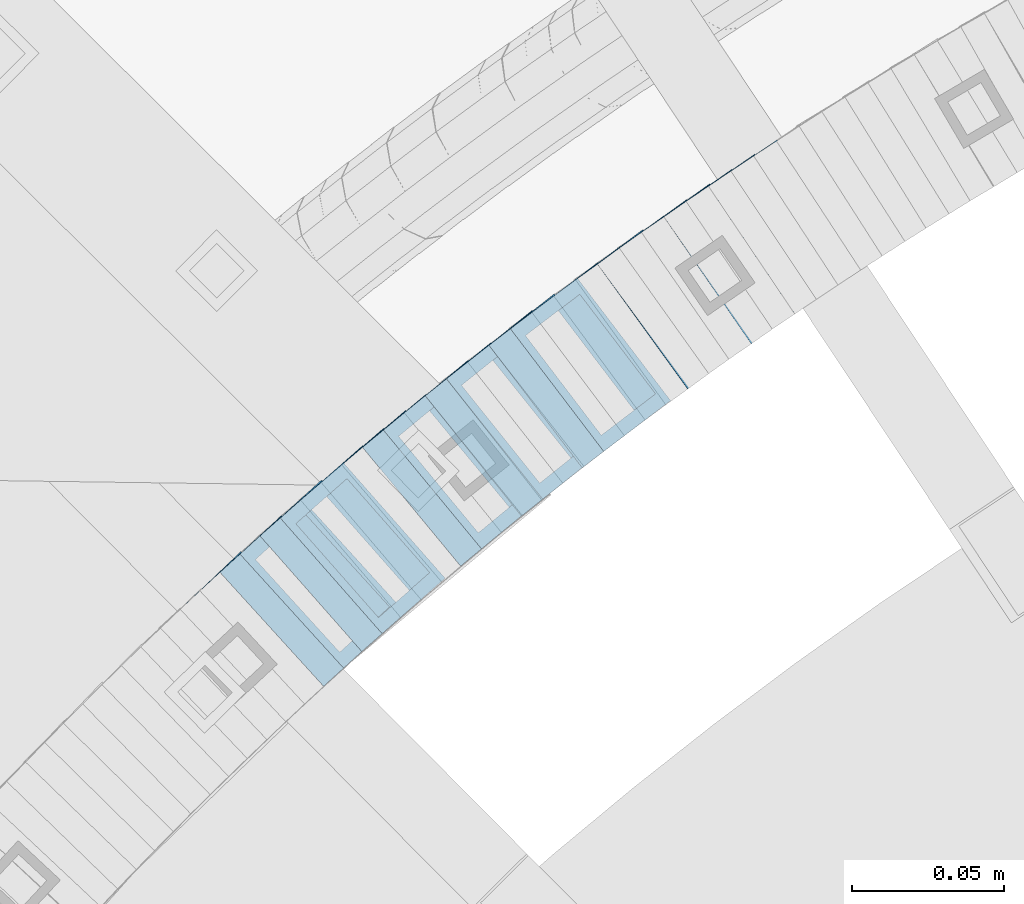
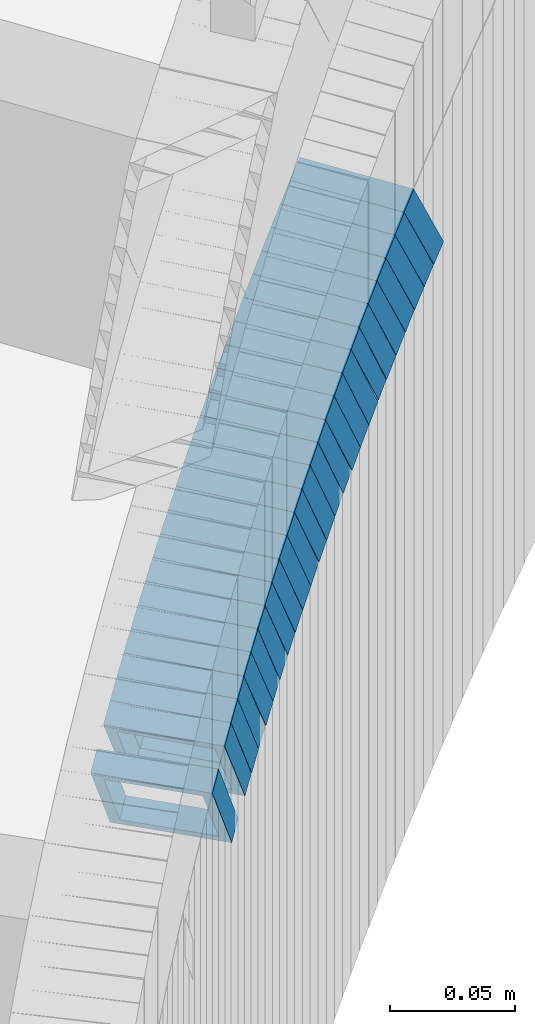
# One storey, part 749 of 975: 25 members.
"""IFC2X3 building model written with IfcOpenShell, lengths in millimetres."""

import ifcopenshell
import ifcopenshell.guid

model = None  # the IFC model being written
_history = None  # IfcOwnerHistory: only IFC2X3 demands one
_inside = {}  # id of a spatial element -> (the spatial element, [elements in it])
_under = {}  # id of a project, library or spatial element -> (it, [spatial elements below it])
_declared = {}  # id of a project -> (the project, [libraries it declares])
_typed = {}  # id of a type object -> (the type object, [elements of that type])
_made_of = {}  # id of a material, layer set ... -> (it, [elements and type objects made of it])


def new_model(schema):
    """Start an empty IFC model of exactly this schema.

    Asked for "IFC4X3", IfcOpenShell would pick the latest addendum, in which some entities
    have other attributes; the version numbers below select the first issue.
    IFC2X3 requires an IfcOwnerHistory on every rooted entity: one is made here for all.
    """
    global model, _history
    if schema == "IFC4X3":
        model = ifcopenshell.file(schema_version=(4, 3, 0, 0))
    else:
        model = ifcopenshell.file(schema=schema)
    _inside.clear()
    _under.clear()
    _declared.clear()
    _typed.clear()
    _made_of.clear()
    _history = None
    if model.schema == "IFC2X3":
        org = make("IfcOrganization", Name="unknown")
        user = make(
            "IfcPersonAndOrganization",
            ThePerson=make("IfcPerson", FamilyName="unknown"),
            TheOrganization=org,
        )
        app = make(
            "IfcApplication",
            ApplicationDeveloper=org,
            Version="unknown",
            ApplicationFullName="unknown",
            ApplicationIdentifier="unknown",
        )
        _history = make(
            "IfcOwnerHistory",
            OwningUser=user,
            OwningApplication=app,
            ChangeAction="ADDED",
            CreationDate=0,
        )
    return model


def make(cls, **values):
    """One entity of the class cls with the attributes given. An attribute that is None is left unset."""
    return model.create_entity(
        cls, **{name: value for name, value in values.items() if value is not None}
    )


def rooted(cls, **values):
    """An entity with a GlobalId (a new one), such as an element, a storey or a relation."""
    return make(cls, GlobalId=ifcopenshell.guid.new(), OwnerHistory=_history, **values)


def si_unit(unit_type, name, prefix=None):
    """IfcSIUnit, for example si_unit("LENGTHUNIT", "METRE", prefix="MILLI")."""
    return make("IfcSIUnit", UnitType=unit_type, Prefix=prefix, Name=name)


def assignment(units):
    """IfcUnitAssignment: the units of a project."""
    return None if units is None else make("IfcUnitAssignment", Units=units)


def point(xyz):
    """IfcCartesianPoint."""
    return None if xyz is None else make("IfcCartesianPoint", Coordinates=xyz)


def direction(xyz):
    """IfcDirection."""
    return None if xyz is None else make("IfcDirection", DirectionRatios=xyz)


def frame(location, z_axis=None, x_axis=None):
    """IfcAxis2Placement3D, a coordinate frame: its origin and axes. An axis left out is left unset."""
    return make(
        "IfcAxis2Placement3D",
        Location=point(location),
        Axis=direction(z_axis),
        RefDirection=direction(x_axis),
    )


def origin_with_axes():
    """The frame at (0, 0, 0) with the z axis (0, 0, 1) and the x axis (1, 0, 0) written out."""
    return frame((0.0, 0.0, 0.0), z_axis=(0.0, 0.0, 1.0), x_axis=(1.0, 0.0, 0.0))


def place(relative_to, where):
    """IfcLocalPlacement: puts the frame where relative to a parent placement (None: the world)."""
    return make(
        "IfcLocalPlacement", PlacementRelTo=relative_to, RelativePlacement=where
    )


def context(
    kind, dimensions, precision=None, world=None, true_north=None, identifier=None
):
    """IfcGeometricRepresentationContext, for example the 3D "Model" context."""
    return make(
        "IfcGeometricRepresentationContext",
        ContextIdentifier=identifier,
        ContextType=kind,
        CoordinateSpaceDimension=dimensions,
        Precision=precision,
        WorldCoordinateSystem=world,
        TrueNorth=true_north,
    )


def subcontext(parent, identifier, kind, view, scale=None):
    """IfcGeometricRepresentationSubContext, for example "Body" below "Model"."""
    return make(
        "IfcGeometricRepresentationSubContext",
        ContextIdentifier=identifier,
        ContextType=kind,
        ParentContext=parent,
        TargetScale=scale,
        TargetView=view,
    )


def project(units=None, contexts=None):
    """IfcProject with its units and contexts."""
    return rooted(
        "IfcProject",
        Name="project",
        RepresentationContexts=contexts,
        UnitsInContext=assignment(units),
    )


def spatial(cls, under=None, at=None, **own):
    """A site, building, storey or space (cls), placed at a placement, below another one or the project."""
    s = rooted(cls, ObjectPlacement=at, **own)
    if under is not None:
        _under.setdefault(under.id(), (under, []))[1].append(s)
    return s


def faces_of(points, faces, orient=None, outer=None):
    """IfcFace entities. A face is a list of loops; a loop is a list of indices into points, from 0.

    orient and outer hold one flag for each loop. By default every Orientation is true, the
    first loop of a face is its IfcFaceOuterBound and the others are IfcFaceBound.
    """
    made = []
    for i, loops in enumerate(faces):
        bounds = []
        for j, loop in enumerate(loops):
            is_outer = j == 0 if outer is None else outer[i][j]
            bounds.append(
                make(
                    "IfcFaceOuterBound" if is_outer else "IfcFaceBound",
                    Bound=make("IfcPolyLoop", Polygon=[points[k] for k in loop]),
                    Orientation=True if orient is None else orient[i][j],
                )
            )
        made.append(make("IfcFace", Bounds=bounds))
    return made


def faceted_brep(points, faces, orient=None, outer=None, voids=None):
    """IfcFacetedBrep: a solid bounded by flat faces; with voids (closed shells), ...WithVoids."""
    shared = [point(p) for p in points]
    hull = make("IfcClosedShell", CfsFaces=faces_of(shared, faces, orient, outer))
    if voids is None:
        return make("IfcFacetedBrep", Outer=hull)
    return make(
        "IfcFacetedBrepWithVoids",
        Outer=hull,
        Voids=[
            make(cls, CfsFaces=faces_of(shared, fs, o, b)) for cls, fs, o, b in voids
        ],
    )


def shape(context_of_items, identifier, shape_type, items):
    """IfcShapeRepresentation: the items that make up one representation, for example the "Body"."""
    return make(
        "IfcShapeRepresentation",
        ContextOfItems=context_of_items,
        RepresentationIdentifier=identifier,
        RepresentationType=shape_type,
        Items=items,
    )


def material(Name=None, Category=None):
    """IfcMaterial."""
    return make("IfcMaterial", Name=Name, Category=Category)


def made_of(thing, what):
    """Note that an element or type object is made of a material, layer set ...; save() writes the relation."""
    if what is not None:
        _made_of.setdefault(what.id(), (what, []))[1].append(thing)
    return thing


def type_object(cls, material=None, **own):
    """A type object (cls), such as IfcWallType, which elements share."""
    return made_of(rooted(cls, **own), material)


def element(
    cls,
    number,
    at=None,
    inside=None,
    cuts=None,
    type_object=None,
    material=None,
    context=None,
    identifier="Body",
    shape_type=None,
    held_by="IfcProductDefinitionShape",
    body=None,
    shapes=None,
    **own,
):
    """One element of the class cls, such as IfcWall. Its Tag is "e" and its number.

    at: its placement. inside: the storey or other place that contains it. cuts: it is an
    opening in that element (IfcRelVoidsElement). A single representation is given by context,
    identifier, shape_type and body (its items); several are given by shapes. held_by: the class
    of the entity that holds the representations. save() writes the other relations.
    """
    e = rooted(cls, Tag="e%d" % number, ObjectPlacement=at, **own)
    if body is not None:
        shapes = [shape(context, identifier, shape_type, body)]
    if shapes is not None:
        e.Representation = make(held_by, Representations=shapes)
    if inside is not None:
        _inside.setdefault(inside.id(), (inside, []))[1].append(e)
    if cuts is not None:
        rooted(
            "IfcRelVoidsElement", RelatingBuildingElement=cuts, RelatedOpeningElement=e
        )
    if type_object is not None:
        _typed.setdefault(type_object.id(), (type_object, []))[1].append(e)
    return made_of(e, material)


def aggregate(whole, parts):
    """IfcRelAggregates: a whole, such as a stair, and the parts it consists of."""
    return rooted("IfcRelAggregates", RelatingObject=whole, RelatedObjects=parts)


def save(model, path):
    """Write the relations noted so far, then the file.

    IfcRelAggregates (storeys below a building ...), IfcRelContainedInSpatialStructure (elements
    in a storey), IfcRelDefinesByType, IfcRelAssociatesMaterial and IfcRelDeclares: one each for
    every whole, place, type object, material and project.
    """
    for whole, parts in _under.values():
        aggregate(whole, parts)
    for where, things in _inside.values():
        rooted(
            "IfcRelContainedInSpatialStructure",
            RelatedElements=things,
            RelatingStructure=where,
        )
    for kind, things in _typed.values():
        rooted("IfcRelDefinesByType", RelatedObjects=things, RelatingType=kind)
    for what, things in _made_of.values():
        rooted("IfcRelAssociatesMaterial", RelatedObjects=things, RelatingMaterial=what)
    for by, libraries in _declared.values():
        rooted("IfcRelDeclares", RelatingContext=by, RelatedDefinitions=libraries)
    model.write(path)


model = new_model("IFC2X3")

# Units and contexts
model_context = context("Model", 3, precision=1e-05, world=origin_with_axes())
body_context = subcontext(model_context, "Body", "Model", "MODEL_VIEW")
ifc_project = project(units=[si_unit("LENGTHUNIT", "METRE", prefix="MILLI"), si_unit("AREAUNIT", "SQUARE_METRE"), si_unit("VOLUMEUNIT", "CUBIC_METRE"), si_unit("MASSUNIT", "GRAM", prefix="KILO"), si_unit("TIMEUNIT", "SECOND"), si_unit("PLANEANGLEUNIT", "RADIAN"), si_unit("SOLIDANGLEUNIT", "STERADIAN"), si_unit("THERMODYNAMICTEMPERATUREUNIT", "DEGREE_CELSIUS"), si_unit("LUMINOUSINTENSITYUNIT", "LUMEN")], contexts=[model_context])

# Site, building, storey
site_placement = place(None, origin_with_axes())
site = spatial("IfcSite", under=ifc_project, at=site_placement, CompositionType="ELEMENT")
building_placement = place(site_placement, origin_with_axes())
building = spatial("IfcBuilding", under=site, at=building_placement, Name="Undefined", CompositionType="ELEMENT")
storey_placement = place(building_placement, origin_with_axes())
storey = spatial("IfcBuildingStorey", under=building, at=storey_placement, Name="Undefined", CompositionType="ELEMENT", Elevation=0.0)

# Members
ifc_material = material()
member_type = type_object("IfcMemberType", Name="HSS2X2X.188_TUBES", PredefinedType="NOTDEFINED")
member_1_placement = place(storey_placement, frame((33945.6299849919, 4556.65921990067, 489.058410364057), z_axis=(-0.567472910723373, 0.823392066755044, 5.72851490687754e-11), x_axis=(0.69183053606331, 0.476802126043426, 0.542245555049391)))
element("IfcMember", 1, at=member_1_placement, inside=storey, type_object=member_type, material=ifc_material, Name="WALL", ObjectType="HSS2X2X.188_TUBES", context=body_context, shape_type="Brep", body=[
    faceted_brep([(0.0, 20.6374999999753, -20.6375000000298), (0.0, -20.6375000000153, -20.6375000000153), (10.6985980389491, -20.6375000000317, -20.6375000000698), (10.6985980389982, 20.6375000000116, -20.6374999999643), (0.0, -20.6374999999825, 20.6375000000335), (10.6985980389818, -20.6374999999989, 20.6374999999789), (0.0, 20.6375000000116, 20.6375000000189), (10.6985980390309, 20.6375000000407, 20.6375000000808), (0.0, 25.3999999999724, -25.4000000000342), (0.0, 25.400000000016, 25.4000000000196), (10.6985980390382, 25.4000000000487, 25.4000000000997), (10.6985980390036, 25.4000000000142, -25.3999999999542), (0.0, -25.399999999976, 25.4000000000378), (10.6985980389763, -25.4000000000033, 25.3999999999724), (0.0, -25.400000000016, -25.4000000000196), (10.6985980389418, -25.400000000036, -25.4000000000851)], [[[0, 1, 2, 3]], [[1, 4, 5, 2]], [[4, 6, 7, 5]], [[6, 0, 3, 7]], [[8, 9, 10, 11]], [[9, 12, 13, 10]], [[12, 14, 15, 13]], [[14, 8, 11, 15]], [[13, 15, 11, 10], [5, 7, 3, 2]], [[14, 12, 9, 8], [6, 4, 1, 0]]]),
])
member_2_placement = place(storey_placement, frame((33938.3475391302, 4551.67792072492, 483.307140848893), z_axis=(-0.572708438875059, 0.819759137821161, 0.0), x_axis=(0.690432747898091, 0.482357124929043, 0.539105021920664)))
element("IfcMember", 2, at=member_2_placement, inside=storey, type_object=member_type, material=ifc_material, Name="WALL", ObjectType="HSS2X2X.188_TUBES", context=body_context, shape_type="Brep", body=[
    faceted_brep([(0.0, 20.6374999999753, -20.6375000000298), (0.0, -20.6375000000153, -20.6375000000153), (10.5744976239494, -20.6375000000207, -20.6375000000335), (10.5744976239657, 20.6375000000098, -20.637500000008), (0.0, -20.6374999999825, 20.6375000000335), (10.5744976239639, -20.6375000000244, 20.6374999999753), (0.0, 20.6375000000116, 20.6375000000189), (10.5744976239803, 20.6374999999989, 20.6374999999935), (0.0, 25.3999999999724, -25.4000000000342), (0.0, 25.400000000016, 25.4000000000196), (10.5744976239857, 25.4000000000051, 25.4000000000015), (10.5744976239675, 25.4000000000124, -25.4000000000051), (0.0, -25.399999999976, 25.4000000000378), (10.5744976239639, -25.4000000000287, 25.3999999999724), (0.0, -25.400000000016, -25.4000000000196), (10.5744976239494, -25.4000000000215, -25.4000000000378)], [[[0, 1, 2, 3]], [[1, 4, 5, 2]], [[4, 6, 7, 5]], [[6, 0, 3, 7]], [[8, 9, 10, 11]], [[9, 12, 13, 10]], [[12, 14, 15, 13]], [[14, 8, 11, 15]], [[13, 15, 11, 10], [5, 7, 3, 2]], [[14, 12, 9, 8], [6, 4, 1, 0]]]),
])
member_3_placement = place(storey_placement, frame((33931.2517820136, 4546.77587397339, 477.575575193324), z_axis=(-0.580182279825393, 0.81448666175488, 0.0), x_axis=(0.683797621876668, 0.487088716912246, 0.543291260902102)))
element("IfcMember", 3, at=member_3_placement, inside=storey, type_object=member_type, material=ifc_material, Name="WALL", ObjectType="HSS2X2X.188_TUBES", context=body_context, shape_type="Brep", body=[
    faceted_brep([(0.0, 20.6374999999753, -20.6375000000298), (0.0, -20.6375000000153, -20.6375000000153), (10.6831643251735, -20.6375000000498, -20.6375000000953), (10.6831643252044, 20.637499999988, -20.6375000000226), (0.0, -20.6374999999825, 20.6375000000335), (10.6831643251935, -20.6375000000135, 20.637499999968), (0.0, 20.6375000000116, 20.6375000000189), (10.6831643252244, 20.6375000000226, 20.6375000000407), (0.0, 25.3999999999724, -25.4000000000342), (0.0, 25.400000000016, 25.4000000000196), (10.6831643252317, 25.4000000000306, 25.4000000000597), (10.6831643252044, 25.3999999999905, -25.4000000000196), (0.0, -25.399999999976, 25.4000000000378), (10.6831643251917, -25.400000000016, 25.3999999999614), (0.0, -25.400000000016, -25.4000000000196), (10.6831643251644, -25.400000000056, -25.4000000001179)], [[[0, 1, 2, 3]], [[1, 4, 5, 2]], [[4, 6, 7, 5]], [[6, 0, 3, 7]], [[8, 9, 10, 11]], [[9, 12, 13, 10]], [[12, 14, 15, 13]], [[14, 8, 11, 15]], [[13, 15, 11, 10], [5, 7, 3, 2]], [[14, 12, 9, 8], [6, 4, 1, 0]]]),
])
member_4_placement = place(storey_placement, frame((33924.0687833559, 4541.69868255447, 471.823674329394), z_axis=(-0.58549055413645, 0.810679228188926, 0.0), x_axis=(0.682257607152639, 0.492741605110064, 0.540120605120664)))
element("IfcMember", 4, at=member_4_placement, inside=storey, type_object=member_type, material=ifc_material, Name="WALL", ObjectType="HSS2X2X.188_TUBES", context=body_context, shape_type="Brep", body=[
    faceted_brep([(0.0, 20.6374999999753, -20.6375000000298), (0.0, -20.6375000000153, -20.6375000000153), (10.5531985672587, -20.6374999999916, -20.6375000000007), (10.5531985672878, 20.6375000000062, -20.6374999999789), (0.0, -20.6374999999825, 20.6375000000335), (10.5531985672114, -20.6375000000353, 20.6374999999171), (0.0, 20.6375000000116, 20.6375000000189), (10.5531985672333, 20.6374999999607, 20.6374999999316), (0.0, 25.3999999999724, -25.4000000000342), (0.0, 25.400000000016, 25.4000000000196), (10.5531985672314, 25.399999999956, 25.3999999999251), (10.5531985672933, 25.4000000000106, -25.3999999999724), (0.0, -25.399999999976, 25.4000000000378), (10.5531985672023, -25.4000000000397, 25.3999999999069), (0.0, -25.400000000016, -25.4000000000196), (10.5531985672642, -25.3999999999851, -25.3999999999869)], [[[0, 1, 2, 3]], [[1, 4, 5, 2]], [[4, 6, 7, 5]], [[6, 0, 3, 7]], [[8, 9, 10, 11]], [[9, 12, 13, 10]], [[12, 14, 15, 13]], [[14, 8, 11, 15]], [[13, 15, 11, 10], [5, 7, 3, 2]], [[14, 12, 9, 8], [6, 4, 1, 0]]]),
])
member_5_placement = place(storey_placement, frame((33916.6775082242, 4536.37463675579, 466.027238584625), z_axis=(-0.587512386110765, 0.809215172970969, -6.74122020427604e-11), x_axis=(0.684097809103072, 0.496673752074743, 0.534158564080343)))
element("IfcMember", 5, at=member_5_placement, inside=storey, type_object=member_type, material=ifc_material, Name="WALL", ObjectType="HSS2X2X.188_TUBES", context=body_context, shape_type="Brep", body=[
    faceted_brep([(0.0, 20.6374999999753, -20.6375000000298), (0.0, -20.6375000000153, -20.6375000000153), (10.6709887076922, -20.6374999999844, -20.6374999999825), (10.6709887076995, 20.6375000000171, -20.6374999999753), (0.0, -20.6374999999825, 20.6375000000335), (10.6709887076922, -20.6374999999971, 20.6375000000153), (0.0, 20.6375000000116, 20.6375000000189), (10.6709887076941, 20.6375000000025, 20.6375000000189), (0.0, 25.3999999999724, -25.4000000000342), (0.0, 25.400000000016, 25.4000000000196), (10.6709887076959, 25.3999999999996, 25.4000000000233), (10.6709887077013, 25.4000000000178, -25.3999999999724), (0.0, -25.399999999976, 25.4000000000378), (10.6709887076904, -25.3999999999978, 25.400000000016), (0.0, -25.400000000016, -25.4000000000196), (10.6709887076959, -25.3999999999796, -25.3999999999796)], [[[0, 1, 2, 3]], [[1, 4, 5, 2]], [[4, 6, 7, 5]], [[6, 0, 3, 7]], [[8, 9, 10, 11]], [[9, 12, 13, 10]], [[12, 14, 15, 13]], [[14, 8, 11, 15]], [[13, 15, 11, 10], [5, 7, 3, 2]], [[14, 12, 9, 8], [6, 4, 1, 0]]]),
])
member_6_placement = place(storey_placement, frame((33952.8187602865, 4561.46194615284, 494.789189186807), z_axis=(-0.559857410943981, 0.8285889689171, 0.0), x_axis=(0.698455183967749, 0.471929177977992, 0.537999262974955)))
element("IfcMember", 6, at=member_6_placement, inside=storey, type_object=member_type, material=ifc_material, Name="WALL", ObjectType="HSS2X2X.188_TUBES", context=body_context, shape_type="Brep", body=[
    faceted_brep([(0.0, 20.6374999999753, -20.6375000000298), (0.0, -20.6375000000153, -20.6375000000153), (10.5948100501191, -20.6375000000335, -20.6375000000844), (10.5948100501555, 20.6374999999971, -20.6375000000116), (0.0, -20.6374999999825, 20.6375000000335), (10.5948100501446, -20.6375000000098, 20.6374999999571), (0.0, 20.6375000000116, 20.6375000000189), (10.5948100501828, 20.6375000000189, 20.6375000000298), (0.0, 25.3999999999724, -25.4000000000342), (0.0, 25.400000000016, 25.4000000000196), (10.5948100501919, 25.4000000000251, 25.4000000000451), (10.5948100501591, 25.3999999999978, -25.4000000000051), (0.0, -25.399999999976, 25.4000000000378), (10.5948100501482, -25.4000000000106, 25.3999999999578), (0.0, -25.400000000016, -25.4000000000196), (10.5948100501118, -25.4000000000378, -25.400000000096)], [[[0, 1, 2, 3]], [[1, 4, 5, 2]], [[4, 6, 7, 5]], [[6, 0, 3, 7]], [[8, 9, 10, 11]], [[9, 12, 13, 10]], [[12, 14, 15, 13]], [[14, 8, 11, 15]], [[13, 15, 11, 10], [5, 7, 3, 2]], [[14, 12, 9, 8], [6, 4, 1, 0]]]),
])
member_7_placement = place(storey_placement, frame((33902.5878218631, 4526.09174665678, 454.541595500078), z_axis=(-0.599999999999955, 0.800000000000033, 3.66071617463603e-14), x_axis=(0.675855260383161, 0.506891445287285, 0.535052081303285)))
element("IfcMember", 7, at=member_7_placement, inside=storey, type_object=member_type, material=ifc_material, Name="WALL", ObjectType="HSS2X2X.188_TUBES", context=body_context, shape_type="Brep", body=[
    faceted_brep([(0.0, 20.6374999999753, -20.6375000000298), (0.0, -20.6375000000153, -20.6375000000153), (10.648004507897, -20.6374999999862, -20.637499999968), (10.6480045078188, 20.6374999999771, -20.6375000000808), (0.0, -20.6374999999825, 20.6375000000335), (10.6480045079406, -20.6374999999698, 20.6375000001062), (0.0, 20.6375000000116, 20.6375000000189), (10.6480045078679, 20.6374999999935, 20.6375000000007), (0.0, 25.3999999999724, -25.4000000000342), (0.0, 25.400000000016, 25.4000000000196), (10.6480045078661, 25.3999999999905, 25.4000000000015), (10.648004507806, 25.3999999999705, -25.4000000000997), (0.0, -25.399999999976, 25.4000000000378), (10.6480045079552, -25.3999999999633, 25.4000000001288), (0.0, -25.400000000016, -25.4000000000196), (10.6480045078988, -25.3999999999814, -25.3999999999651)], [[[0, 1, 2, 3]], [[1, 4, 5, 2]], [[4, 6, 7, 5]], [[6, 0, 3, 7]], [[8, 9, 10, 11]], [[9, 12, 13, 10]], [[12, 14, 15, 13]], [[14, 8, 11, 15]], [[13, 15, 11, 10], [5, 7, 3, 2]], [[14, 12, 9, 8], [6, 4, 1, 0]]]),
])
member_8_placement = place(storey_placement, frame((33895.6378623201, 4520.91998783105, 448.89658431469), z_axis=(-0.605367471213059, 0.795946119280134, 0.0), x_axis=(0.670707309990764, 0.510115418993113, 0.538455163992726)))
element("IfcMember", 8, at=member_8_placement, inside=storey, type_object=member_type, material=ifc_material, Name="WALL", ObjectType="HSS2X2X.188_TUBES", context=body_context, shape_type="Brep", body=[
    faceted_brep([(0.0, 20.6374999999753, -20.6375000000298), (0.0, -20.6375000000153, -20.6375000000153), (10.5948100501191, -20.6375000000335, -20.6375000000844), (10.5948100501555, 20.6374999999971, -20.6375000000116), (0.0, -20.6374999999825, 20.6375000000335), (10.5948100501446, -20.6375000000098, 20.6374999999571), (0.0, 20.6375000000116, 20.6375000000189), (10.5948100501828, 20.6375000000189, 20.6375000000298), (0.0, 25.3999999999724, -25.4000000000342), (0.0, 25.400000000016, 25.4000000000196), (10.5948100501919, 25.4000000000251, 25.4000000000451), (10.5948100501591, 25.3999999999978, -25.4000000000051), (0.0, -25.399999999976, 25.4000000000378), (10.5948100501482, -25.4000000000106, 25.3999999999578), (0.0, -25.400000000016, -25.4000000000196), (10.5948100501118, -25.4000000000378, -25.400000000096)], [[[0, 1, 2, 3]], [[1, 4, 5, 2]], [[4, 6, 7, 5]], [[6, 0, 3, 7]], [[8, 9, 10, 11]], [[9, 12, 13, 10]], [[12, 14, 15, 13]], [[14, 8, 11, 15]], [[13, 15, 11, 10], [5, 7, 3, 2]], [[14, 12, 9, 8], [6, 4, 1, 0]]]),
])
member_9_placement = place(storey_placement, frame((33888.6724401165, 4515.62234277477, 443.205570956088), z_axis=(-0.605367471213059, 0.795946119280134, 0.0), x_axis=(0.66729205421176, 0.507517900161024, 0.545111819172905)))
element("IfcMember", 9, at=member_9_placement, inside=storey, type_object=member_type, material=ifc_material, Name="WALL", ObjectType="HSS2X2X.188_TUBES", context=body_context, shape_type="Brep", body=[
    faceted_brep([(0.0, 20.6374999999753, -20.6375000000298), (0.0, -20.6375000000153, -20.6375000000153), (10.6395488625676, -20.6374999999771, -20.6374999999716), (10.6395488625531, 20.6374999999916, -20.6375000000189), (0.0, -20.6374999999825, 20.6375000000335), (10.6395488625731, -20.6374999999844, 20.6375000000153), (0.0, 20.6375000000116, 20.6375000000189), (10.6395488625585, 20.6374999999825, 20.637499999968), (0.0, 25.3999999999724, -25.4000000000342), (0.0, 25.400000000016, 25.4000000000196), (10.6395488625567, 25.3999999999778, 25.3999999999614), (10.6395488625494, 25.3999999999887, -25.4000000000233), (0.0, -25.399999999976, 25.4000000000378), (10.6395488625749, -25.3999999999851, 25.400000000016), (0.0, -25.400000000016, -25.4000000000196), (10.6395488625658, -25.399999999976, -25.3999999999687)], [[[0, 1, 2, 3]], [[1, 4, 5, 2]], [[4, 6, 7, 5]], [[6, 0, 3, 7]], [[8, 9, 10, 11]], [[9, 12, 13, 10]], [[12, 14, 15, 13]], [[14, 8, 11, 15]], [[13, 15, 11, 10], [5, 7, 3, 2]], [[14, 12, 9, 8], [6, 4, 1, 0]]]),
])
member_10_placement = place(storey_placement, frame((33910.0178610049, 4531.62510266129, 460.448564624512), z_axis=(-0.598192606862824, 0.801352360135452, 1.24999814943294e-10), x_axis=(0.670468028116059, 0.500490218086671, 0.547706276094879)))
element("IfcMember", 10, at=member_10_placement, inside=storey, type_object=member_type, material=ifc_material, Name="WALL", ObjectType="HSS2X2X.188_TUBES", context=body_context, shape_type="Brep", body=[
    faceted_brep([(0.0, 20.6374999999753, -20.6375000000298), (0.0, -20.6375000000153, -20.6375000000153), (10.5948100501191, -20.6375000000335, -20.6375000000844), (10.5948100501555, 20.6374999999971, -20.6375000000116), (0.0, -20.6374999999825, 20.6375000000335), (10.5948100501446, -20.6375000000098, 20.6374999999571), (0.0, 20.6375000000116, 20.6375000000189), (10.5948100501828, 20.6375000000189, 20.6375000000298), (0.0, 25.3999999999724, -25.4000000000342), (0.0, 25.400000000016, 25.4000000000196), (10.5948100501919, 25.4000000000251, 25.4000000000451), (10.5948100501591, 25.3999999999978, -25.4000000000051), (0.0, -25.399999999976, 25.4000000000378), (10.5948100501482, -25.4000000000106, 25.3999999999578), (0.0, -25.400000000016, -25.4000000000196), (10.5948100501118, -25.4000000000378, -25.400000000096)], [[[0, 1, 2, 3]], [[1, 4, 5, 2]], [[4, 6, 7, 5]], [[6, 0, 3, 7]], [[8, 9, 10, 11]], [[9, 12, 13, 10]], [[12, 14, 15, 13]], [[14, 8, 11, 15]], [[13, 15, 11, 10], [5, 7, 3, 2]], [[14, 12, 9, 8], [6, 4, 1, 0]]]),
])
member_11_placement = place(storey_placement, frame((33881.7379071258, 4510.4469555239, 437.409101934961), z_axis=(-0.61782155188774, 0.786318338857122, 0.0), x_axis=(0.66220690709887, 0.520305427077975, 0.539225625080778)))
element("IfcMember", 11, at=member_11_placement, inside=storey, type_object=member_type, material=ifc_material, Name="WALL", ObjectType="HSS2X2X.188_TUBES", context=body_context, shape_type="Brep", body=[
    faceted_brep([(0.0, 20.6374999999753, -20.6375000000298), (0.0, -20.6375000000153, -20.6375000000153), (10.5744976239494, -20.6375000000207, -20.6375000000335), (10.5744976239657, 20.6375000000098, -20.637500000008), (0.0, -20.6374999999825, 20.6375000000335), (10.5744976239639, -20.6375000000244, 20.6374999999753), (0.0, 20.6375000000116, 20.6375000000189), (10.5744976239803, 20.6374999999989, 20.6374999999935), (0.0, 25.3999999999724, -25.4000000000342), (0.0, 25.400000000016, 25.4000000000196), (10.5744976239857, 25.4000000000051, 25.4000000000015), (10.5744976239675, 25.4000000000124, -25.4000000000051), (0.0, -25.399999999976, 25.4000000000378), (10.5744976239639, -25.4000000000287, 25.3999999999724), (0.0, -25.400000000016, -25.4000000000196), (10.5744976239494, -25.4000000000215, -25.4000000000378)], [[[0, 1, 2, 3]], [[1, 4, 5, 2]], [[4, 6, 7, 5]], [[6, 0, 3, 7]], [[8, 9, 10, 11]], [[9, 12, 13, 10]], [[12, 14, 15, 13]], [[14, 8, 11, 15]], [[13, 15, 11, 10], [5, 7, 3, 2]], [[14, 12, 9, 8], [6, 4, 1, 0]]]),
])
for number, where, z_axis, x_axis, name in (
    (12, (33874.785126831, 4505.03733241941, 431.666016178888), (-0.624695047600639, 0.780868809406058, -1.82944404514274e-10), (0.658942104066478, 0.527153683053066, 0.53656714205403), "WALL"),
    (13, (33867.785126831, 4499.4373324194, 425.966016178922), (-0.624695047600639, 0.780868809406058, -1.82944404514274e-10), (0.658942104066478, 0.527153683053066, 0.53656714205403), "WALL"),
):
    element("IfcMember", number, at=place(storey_placement, frame(where, z_axis=z_axis, x_axis=x_axis)), inside=storey, type_object=member_type, material=ifc_material, Name=name, ObjectType="HSS2X2X.188_TUBES", context=body_context, shape_type="Brep", body=[
        faceted_brep([(0.0, 20.6374999999753, -20.6375000000298), (0.0, -20.6375000000153, -20.6375000000153), (10.6216759506497, -20.637499999968, -20.6374999999534), (10.6216759506497, 20.6375000000262, -20.6374999999643), (0.0, -20.6374999999825, 20.6375000000335), (10.6216759506169, -20.6374999999935, 20.637500000008), (0.0, 20.6375000000116, 20.6375000000189), (10.6216759506242, 20.6375000000007, 20.6374999999971), (0.0, 25.3999999999724, -25.4000000000342), (0.0, 25.400000000016, 25.4000000000196), (10.6216759506169, 25.3999999999978, 25.3999999999869), (10.6216759506533, 25.4000000000269, -25.3999999999614), (0.0, -25.399999999976, 25.4000000000378), (10.6216759506242, -25.3999999999942, 25.4000000000051), (0.0, -25.400000000016, -25.4000000000196), (10.6216759506569, -25.3999999999614, -25.3999999999432)], [[[0, 1, 2, 3]], [[1, 4, 5, 2]], [[4, 6, 7, 5]], [[6, 0, 3, 7]], [[8, 9, 10, 11]], [[9, 12, 13, 10]], [[12, 14, 15, 13]], [[14, 8, 11, 15]], [[13, 15, 11, 10], [5, 7, 3, 2]], [[14, 12, 9, 8], [6, 4, 1, 0]]]),
    ])
for number, where, z_axis, x_axis, name in (
    (14, (33861.1611705511, 4494.18394870685, 420.329568218791), (-0.630168888270572, 0.776458094333385, 0.0), (0.6502204311038, 0.527715132084063, 0.546562101087047), "WALL"),
    (15, (33854.1717650668, 4488.56507410266, 414.47602441689), (-0.636881447053034, 0.770961751580216, -1.96311134459392e-10), (0.650278179269491, 0.537186322222534, 0.537186322222545), "WALL"),
    (16, (33847.2717650668, 4482.86507410269, 408.776024416921), (-0.636881447053034, 0.770961751580216, -1.96311134459392e-10), (0.650278179269491, 0.537186322222534, 0.537186322222545), "WALL"),
):
    element("IfcMember", number, at=place(storey_placement, frame(where, z_axis=z_axis, x_axis=x_axis)), inside=storey, type_object=member_type, material=ifc_material, Name=name, ObjectType="HSS2X2X.188_TUBES", context=body_context, shape_type="Brep", body=[
        faceted_brep([(0.0, 20.6374999999753, -20.6375000000298), (0.0, -20.6375000000153, -20.6375000000153), (10.6061303028146, -20.6374999999571, -20.6374999999643), (10.6061303027491, 20.6374999999971, -20.6375000000007), (0.0, -20.6374999999825, 20.6375000000335), (10.6061303027855, -20.6374999999825, 20.6375000000116), (0.0, 20.6375000000116, 20.6375000000189), (10.6061303027236, 20.637499999968, 20.6374999999716), (0.0, 25.3999999999724, -25.4000000000342), (0.0, 25.400000000016, 25.4000000000196), (10.6061303027163, 25.3999999999651, 25.3999999999651), (10.6061303027454, 25.3999999999942, -25.4000000000051), (0.0, -25.399999999976, 25.4000000000378), (10.6061303027891, -25.3999999999796, 25.4000000000124), (0.0, -25.400000000016, -25.4000000000196), (10.6061303028182, -25.3999999999505, -25.3999999999542)], [[[0, 1, 2, 3]], [[1, 4, 5, 2]], [[4, 6, 7, 5]], [[6, 0, 3, 7]], [[8, 9, 10, 11]], [[9, 12, 13, 10]], [[12, 14, 15, 13]], [[14, 8, 11, 15]], [[13, 15, 11, 10], [5, 7, 3, 2]], [[14, 12, 9, 8], [6, 4, 1, 0]]]),
    ])
member_12_placement = place(storey_placement, frame((33840.6134666193, 4477.41079293963, 403.129612526302), z_axis=(-0.642398813105216, 0.766370514125517, 0.0), x_axis=(0.644788773974838, 0.540484706978833, 0.540484706978866)))
element("IfcMember", 17, at=member_12_placement, inside=storey, type_object=member_type, material=ifc_material, Name="WALL", ObjectType="HSS2X2X.188_TUBES", context=body_context, shape_type="Brep", body=[
    faceted_brep([(0.0, 20.6374999999753, -20.6375000000298), (0.0, -20.6375000000153, -20.6375000000153), (10.5531985672587, -20.6374999999916, -20.6375000000007), (10.5531985672878, 20.6375000000062, -20.6374999999789), (0.0, -20.6374999999825, 20.6375000000335), (10.5531985672114, -20.6375000000353, 20.6374999999171), (0.0, 20.6375000000116, 20.6375000000189), (10.5531985672333, 20.6374999999607, 20.6374999999316), (0.0, 25.3999999999724, -25.4000000000342), (0.0, 25.400000000016, 25.4000000000196), (10.5531985672314, 25.399999999956, 25.3999999999251), (10.5531985672933, 25.4000000000106, -25.3999999999724), (0.0, -25.399999999976, 25.4000000000378), (10.5531985672023, -25.4000000000397, 25.3999999999069), (0.0, -25.400000000016, -25.4000000000196), (10.5531985672642, -25.3999999999851, -25.3999999999869)], [[[0, 1, 2, 3]], [[1, 4, 5, 2]], [[4, 6, 7, 5]], [[6, 0, 3, 7]], [[8, 9, 10, 11]], [[9, 12, 13, 10]], [[12, 14, 15, 13]], [[14, 8, 11, 15]], [[13, 15, 11, 10], [5, 7, 3, 2]], [[14, 12, 9, 8], [6, 4, 1, 0]]]),
])
member_13_placement = place(storey_placement, frame((33833.9787992229, 4471.9053047889, 397.393282236276), z_axis=(-0.648946606019832, 0.760833952012751, -4.42406644651783e-12), x_axis=(0.638223397472695, 0.544367015403408, 0.544367015403392)))
element("IfcMember", 18, at=member_13_placement, inside=storey, type_object=member_type, material=ifc_material, Name="WALL", ObjectType="HSS2X2X.188_TUBES", context=body_context, shape_type="Brep", body=[
    faceted_brep([(0.0, 20.6374999999753, -20.6375000000298), (0.0, -20.6375000000153, -20.6375000000153), (10.648004507897, -20.6374999999862, -20.637499999968), (10.6480045078188, 20.6374999999771, -20.6375000000808), (0.0, -20.6374999999825, 20.6375000000335), (10.6480045079406, -20.6374999999698, 20.6375000001062), (0.0, 20.6375000000116, 20.6375000000189), (10.6480045078679, 20.6374999999935, 20.6375000000007), (0.0, 25.3999999999724, -25.4000000000342), (0.0, 25.400000000016, 25.4000000000196), (10.6480045078661, 25.3999999999905, 25.4000000000015), (10.648004507806, 25.3999999999705, -25.4000000000997), (0.0, -25.399999999976, 25.4000000000378), (10.6480045079552, -25.3999999999633, 25.4000000001288), (0.0, -25.400000000016, -25.4000000000196), (10.6480045078988, -25.3999999999814, -25.3999999999651)], [[[0, 1, 2, 3]], [[1, 4, 5, 2]], [[4, 6, 7, 5]], [[6, 0, 3, 7]], [[8, 9, 10, 11]], [[9, 12, 13, 10]], [[12, 14, 15, 13]], [[14, 8, 11, 15]], [[13, 15, 11, 10], [5, 7, 3, 2]], [[14, 12, 9, 8], [6, 4, 1, 0]]]),
])
member_14_placement = place(storey_placement, frame((33827.0843535441, 4466.0768641389, 391.539700391991), z_axis=(-0.655353317111744, 0.755322467394313, 1.10174880774139e-10), x_axis=(0.638167183753212, 0.553703879785767, 0.534934256793004)))
element("IfcMember", 19, at=member_14_placement, inside=storey, type_object=member_type, material=ifc_material, Name="WALL", ObjectType="HSS2X2X.188_TUBES", context=body_context, shape_type="Brep", body=[
    faceted_brep([(0.0, 20.6374999999753, -20.6375000000298), (0.0, -20.6375000000153, -20.6375000000153), (10.6625512894789, -20.6374999999625, -20.6374999999389), (10.6625512893879, 20.6374999999789, -20.6375000000371), (0.0, -20.6374999999825, 20.6375000000335), (10.6625512894352, -20.6374999999989, 20.6375000000153), (0.0, 20.6375000000116, 20.6375000000189), (10.6625512893443, 20.6374999999443, 20.6374999999134), (0.0, 25.3999999999724, -25.4000000000342), (0.0, 25.400000000016, 25.4000000000196), (10.6625512893297, 25.3999999999342, 25.3999999998996), (10.6625512893916, 25.399999999976, -25.4000000000415), (0.0, -25.399999999976, 25.4000000000378), (10.6625512894389, -25.399999999996, 25.400000000016), (0.0, -25.400000000016, -25.4000000000196), (10.6625512894971, -25.3999999999523, -25.3999999999214)], [[[0, 1, 2, 3]], [[1, 4, 5, 2]], [[4, 6, 7, 5]], [[6, 0, 3, 7]], [[8, 9, 10, 11]], [[9, 12, 13, 10]], [[12, 14, 15, 13]], [[14, 8, 11, 15]], [[13, 15, 11, 10], [5, 7, 3, 2]], [[14, 12, 9, 8], [6, 4, 1, 0]]]),
])
member_15_placement = place(storey_placement, frame((33813.9471460428, 4454.64026952205, 380.200408574421), z_axis=(-0.660880368115947, 0.750491265131667, 0.0), x_axis=(0.629336902981407, 0.554192197983901, 0.54479910998417)))
element("IfcMember", 20, at=member_15_placement, inside=storey, type_object=member_type, material=ifc_material, Name="WALL", ObjectType="HSS2X2X.188_TUBES", context=body_context, shape_type="Brep", body=[
    faceted_brep([(0.0, 20.6374999999753, -20.6375000000298), (0.0, -20.6375000000153, -20.6375000000153), (10.648004507897, -20.6374999999862, -20.637499999968), (10.6480045078188, 20.6374999999771, -20.6375000000808), (0.0, -20.6374999999825, 20.6375000000335), (10.6480045079406, -20.6374999999698, 20.6375000001062), (0.0, 20.6375000000116, 20.6375000000189), (10.6480045078679, 20.6374999999935, 20.6375000000007), (0.0, 25.3999999999724, -25.4000000000342), (0.0, 25.400000000016, 25.4000000000196), (10.6480045078661, 25.3999999999905, 25.4000000000015), (10.648004507806, 25.3999999999705, -25.4000000000997), (0.0, -25.399999999976, 25.4000000000378), (10.6480045079552, -25.3999999999633, 25.4000000001288), (0.0, -25.400000000016, -25.4000000000196), (10.6480045078988, -25.3999999999814, -25.3999999999651)], [[[0, 1, 2, 3]], [[1, 4, 5, 2]], [[4, 6, 7, 5]], [[6, 0, 3, 7]], [[8, 9, 10, 11]], [[9, 12, 13, 10]], [[12, 14, 15, 13]], [[14, 8, 11, 15]], [[13, 15, 11, 10], [5, 7, 3, 2]], [[14, 12, 9, 8], [6, 4, 1, 0]]]),
])
member_16_placement = place(storey_placement, frame((33820.5202661276, 4460.42853944747, 385.89152150901), z_axis=(-0.660880368115947, 0.750491265131667, 0.0), x_axis=(0.632554178015133, 0.557025321013384, 0.538143107012936)))
element("IfcMember", 21, at=member_16_placement, inside=storey, type_object=member_type, material=ifc_material, Name="WALL", ObjectType="HSS2X2X.188_TUBES", context=body_context, shape_type="Brep", body=[
    faceted_brep([(0.0, 20.6374999999753, -20.6375000000298), (0.0, -20.6375000000153, -20.6375000000153), (10.5948100501191, -20.6375000000335, -20.6375000000844), (10.5948100501555, 20.6374999999971, -20.6375000000116), (0.0, -20.6374999999825, 20.6375000000335), (10.5948100501446, -20.6375000000098, 20.6374999999571), (0.0, 20.6375000000116, 20.6375000000189), (10.5948100501828, 20.6375000000189, 20.6375000000298), (0.0, 25.3999999999724, -25.4000000000342), (0.0, 25.400000000016, 25.4000000000196), (10.5948100501919, 25.4000000000251, 25.4000000000451), (10.5948100501591, 25.3999999999978, -25.4000000000051), (0.0, -25.399999999976, 25.4000000000378), (10.5948100501482, -25.4000000000106, 25.3999999999578), (0.0, -25.400000000016, -25.4000000000196), (10.5948100501118, -25.4000000000378, -25.400000000096)], [[[0, 1, 2, 3]], [[1, 4, 5, 2]], [[4, 6, 7, 5]], [[6, 0, 3, 7]], [[8, 9, 10, 11]], [[9, 12, 13, 10]], [[12, 14, 15, 13]], [[14, 8, 11, 15]], [[13, 15, 11, 10], [5, 7, 3, 2]], [[14, 12, 9, 8], [6, 4, 1, 0]]]),
])
member_17_placement = place(storey_placement, frame((33794.3302107902, 4437.15272480305, 362.958410364721), z_axis=(-0.678742109073749, 0.734376708079797, 0.0), x_axis=(0.617038045912108, 0.570292738918771, 0.542245554922761)))
element("IfcMember", 22, at=member_17_placement, inside=storey, type_object=member_type, material=ifc_material, Name="WALL", ObjectType="HSS2X2X.188_TUBES", context=body_context, shape_type="Brep", body=[
    faceted_brep([(0.0, 20.6374999999753, -20.6375000000298), (0.0, -20.6375000000153, -20.6375000000153), (10.6985980389491, -20.6375000000317, -20.6375000000698), (10.6985980389982, 20.6375000000116, -20.6374999999643), (0.0, -20.6374999999825, 20.6375000000335), (10.6985980389818, -20.6374999999989, 20.6374999999789), (0.0, 20.6375000000116, 20.6375000000189), (10.6985980390309, 20.6375000000407, 20.6375000000808), (0.0, 25.3999999999724, -25.4000000000342), (0.0, 25.400000000016, 25.4000000000196), (10.6985980390382, 25.4000000000487, 25.4000000000997), (10.6985980390036, 25.4000000000142, -25.3999999999542), (0.0, -25.399999999976, 25.4000000000378), (10.6985980389763, -25.4000000000033, 25.3999999999724), (0.0, -25.400000000016, -25.4000000000196), (10.6985980389418, -25.400000000036, -25.4000000000851)], [[[0, 1, 2, 3]], [[1, 4, 5, 2]], [[4, 6, 7, 5]], [[6, 0, 3, 7]], [[8, 9, 10, 11]], [[9, 12, 13, 10]], [[12, 14, 15, 13]], [[14, 8, 11, 15]], [[13, 15, 11, 10], [5, 7, 3, 2]], [[14, 12, 9, 8], [6, 4, 1, 0]]]),
])
for number, where, z_axis, x_axis, name in (
    (23, (33800.7818877804, 4442.96347074741, 368.696974297999), (-0.672672794195408, 0.739940073214948, 0.0), (0.623502221313887, 0.566820201285135, 0.538479191270867), "WALL"),
    (24, (33807.3818877804, 4448.96347074743, 374.396974297963), (-0.672672794195408, 0.739940073214948, 0.0), (0.623502221313887, 0.566820201285135, 0.538479191270867), "WALL"),
):
    element("IfcMember", number, at=place(storey_placement, frame(where, z_axis=z_axis, x_axis=x_axis)), inside=storey, type_object=member_type, material=ifc_material, Name=name, ObjectType="HSS2X2X.188_TUBES", context=body_context, shape_type="Brep", body=[
        faceted_brep([(0.0, 20.6374999999753, -20.6375000000298), (0.0, -20.6375000000153, -20.6375000000153), (10.5948100501191, -20.6375000000335, -20.6375000000844), (10.5948100501555, 20.6374999999971, -20.6375000000116), (0.0, -20.6374999999825, 20.6375000000335), (10.5948100501446, -20.6375000000098, 20.6374999999571), (0.0, 20.6375000000116, 20.6375000000189), (10.5948100501828, 20.6375000000189, 20.6375000000298), (0.0, 25.3999999999724, -25.4000000000342), (0.0, 25.400000000016, 25.4000000000196), (10.5948100501919, 25.4000000000251, 25.4000000000451), (10.5948100501591, 25.3999999999978, -25.4000000000051), (0.0, -25.399999999976, 25.4000000000378), (10.5948100501482, -25.4000000000106, 25.3999999999578), (0.0, -25.400000000016, -25.4000000000196), (10.5948100501118, -25.4000000000378, -25.400000000096)], [[[0, 1, 2, 3]], [[1, 4, 5, 2]], [[4, 6, 7, 5]], [[6, 0, 3, 7]], [[8, 9, 10, 11]], [[9, 12, 13, 10]], [[12, 14, 15, 13]], [[14, 8, 11, 15]], [[13, 15, 11, 10], [5, 7, 3, 2]], [[14, 12, 9, 8], [6, 4, 1, 0]]]),
    ])
member_18_placement = place(storey_placement, frame((33781.4766904354, 4425.28752991391, 351.461520391378), z_axis=(-0.690210929024432, 0.723608232025611, 0.0), x_axis=(0.607901556062941, 0.579844561059924, 0.542435234056085)))
element("IfcMember", 25, at=member_18_placement, inside=storey, type_object=member_type, material=ifc_material, Name="WALL", ObjectType="HSS2X2X.188_TUBES", context=body_context, shape_type="Brep", body=[
    faceted_brep([(0.0, 20.6374999999753, -20.6375000000298), (0.0, -20.6375000000153, -20.6375000000153), (10.6906501205649, -20.6374999999844, -20.637499999968), (10.690650120574, 20.6375000000098, -20.6374999999716), (0.0, -20.6374999999825, 20.6375000000335), (10.6906501205467, -20.6374999999844, 20.637500000008), (0.0, 20.6375000000116, 20.6375000000189), (10.6906501205558, 20.637500000008, 20.6375000000007), (0.0, 25.3999999999724, -25.4000000000342), (0.0, 25.400000000016, 25.4000000000196), (10.6906501205522, 25.4000000000087, 25.3999999999978), (10.6906501205813, 25.4000000000124, -25.3999999999651), (0.0, -25.399999999976, 25.4000000000378), (10.6906501205431, -25.3999999999833, 25.4000000000051), (0.0, -25.400000000016, -25.4000000000196), (10.6906501205704, -25.3999999999833, -25.3999999999614)], [[[0, 1, 2, 3]], [[1, 4, 5, 2]], [[4, 6, 7, 5]], [[6, 0, 3, 7]], [[8, 9, 10, 11]], [[9, 12, 13, 10]], [[12, 14, 15, 13]], [[14, 8, 11, 15]], [[13, 15, 11, 10], [5, 7, 3, 2]], [[14, 12, 9, 8], [6, 4, 1, 0]]]),
])

save(model, "model.ifc")
